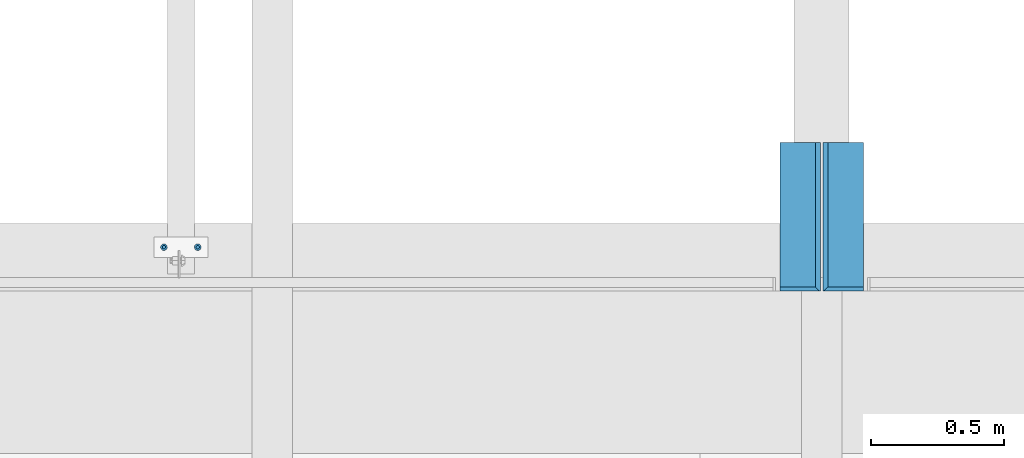
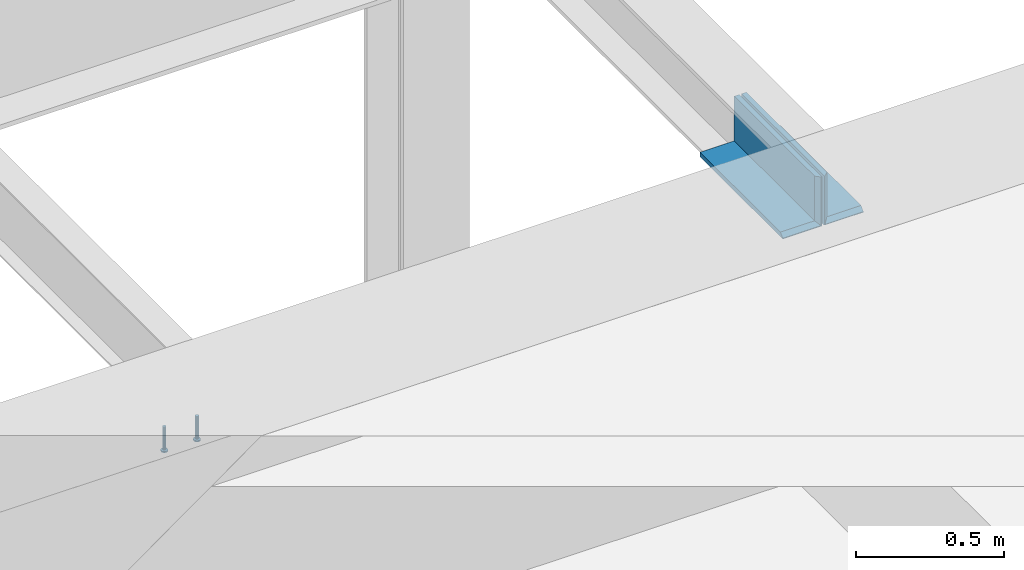
# One storey, part 1286 of 1763: 4 beams, 3 elements without a shape of their own.
"""IFC2X3 building model written with IfcOpenShell, lengths in millimetres."""

from ifc_helpers import new_model, si_unit, frame, origin_with_axes, place, context, subcontext, project, spatial, faceted_brep, material, type_object, element, aggregate, save


model = new_model("IFC2X3")

# Units and contexts
model_context = context("Model", 3, precision=1e-05, world=origin_with_axes())
body_context = subcontext(model_context, "Body", "Model", "MODEL_VIEW")
ifc_project = project(units=[si_unit("LENGTHUNIT", "METRE", prefix="MILLI"), si_unit("AREAUNIT", "SQUARE_METRE"), si_unit("VOLUMEUNIT", "CUBIC_METRE"), si_unit("MASSUNIT", "GRAM", prefix="KILO"), si_unit("TIMEUNIT", "SECOND"), si_unit("PLANEANGLEUNIT", "RADIAN"), si_unit("SOLIDANGLEUNIT", "STERADIAN"), si_unit("THERMODYNAMICTEMPERATUREUNIT", "DEGREE_CELSIUS"), si_unit("LUMINOUSINTENSITYUNIT", "LUMEN")], contexts=[model_context])

# Site, building, storey
site_placement = place(None, origin_with_axes())
site = spatial("IfcSite", under=ifc_project, at=site_placement, CompositionType="ELEMENT")
building_placement = place(site_placement, origin_with_axes())
building = spatial("IfcBuilding", under=site, at=building_placement, Name="Undefined", CompositionType="ELEMENT")
storey_placement = place(building_placement, origin_with_axes())
storey = spatial("IfcBuildingStorey", under=building, at=storey_placement, Name="Undefined", CompositionType="ELEMENT", Elevation=0.0)

# Assembly, beams
assembly_1_placement = place(storey_placement, origin_with_axes())
assembly_1 = element("IfcElementAssembly", 1, at=assembly_1_placement, inside=storey, Name="EMBED PLATE", AssemblyPlace="NOTDEFINED", PredefinedType="RIGID_FRAME")
ifc_material_1 = material(Name="STEEL/A108")
beam_type_1 = type_object("IfcBeamType", PredefinedType="NOTDEFINED")
beam_1_placement = place(assembly_1_placement, frame((-37295.1039434168, 27444.6999954224, 4879.975), z_axis=(1.0, 0.0, 0.0), x_axis=(0.0, 0.0, -1.0)))
beam_1 = element("IfcBeam", 2, at=beam_1_placement, type_object=beam_type_1, material=ifc_material_1, Name="HEADED STUD ANCHOR", context=body_context, shape_type="Brep", body=[
    faceted_brep([(0.0, -3.1800000667572, 5.5), (0.0, -5.5, 3.1800000667572), (94.4880000000003, -5.5, 3.1800000667572), (94.4880000000003, -3.1800000667572, 5.5), (0.0, -6.34999999999491, 1.45519152283669e-11), (94.4880000000003, -6.34999990463257, 0.0), (0.0, -5.5, -3.1800000667572), (94.4880000000003, -5.5, -3.1800000667572), (0.0, -3.1800000667572, -5.5), (94.4880000000003, -3.1800000667572, -5.5), (0.0, 0.0, -6.34999990463257), (94.4880000000003, 0.0, -6.34999990463257), (0.0, 3.1800000667572, -5.5), (94.4880000000003, 3.1800000667572, -5.5), (0.0, 5.5, -3.1800000667572), (94.4880000000003, 5.5, -3.1800000667572), (0.0, 6.34999999999491, -2.91038304567337e-11), (94.4880000000003, 6.34999990463257, 0.0), (0.0, 5.5, 3.1800000667572), (94.4880000000003, 5.5, 3.1800000667572), (0.0, 3.1800000667572, 5.5), (94.4880000000003, 3.1800000667572, 5.5), (0.0, 0.0, 6.34999990463257), (94.4880000000003, 0.0, 6.34999990463257), (96.5200000000004, -10.9899997711182, 6.34999990463257), (96.5200000000004, -6.34000015258789, 10.9899997711182), (96.5200000000004, -12.6999998092651, 0.0), (96.5200000000004, -10.9899997711182, -6.34999990463257), (96.5200000000004, -6.34000015258789, -10.9899997711182), (96.5200000000004, 0.0, -12.6899995803833), (96.5200000000004, 6.34000015258789, -10.9899997711182), (96.5200000000004, 10.9899997711182, -6.34999990463257), (96.5200000000004, 12.6999998092651, 0.0), (96.5200000000004, 10.9899997711182, 6.34999990463257), (96.5200000000004, 6.34000015258789, 10.9899997711182), (96.5200000000004, 0.0, 12.6899995803833), (101.6, -10.9899997711182, 6.34999990463257), (101.6, -6.34000015258789, 10.9899997711182), (101.6, -12.6999998092651, 0.0), (101.6, -10.9899997711182, -6.34999990463257), (101.6, -6.34000015258789, -10.9899997711182), (101.6, 0.0, -12.6899995803833), (101.6, 6.34000015258789, -10.9899997711182), (101.6, 10.9899997711182, -6.34999990463257), (101.6, 12.6999998092651, 0.0), (101.6, 10.9899997711182, 6.34999990463257), (101.6, 6.34000015258789, 10.9899997711182), (101.6, 0.0, 12.6899995803833)], [[[0, 1, 2, 3]], [[1, 4, 5, 2]], [[4, 6, 7, 5]], [[6, 8, 9, 7]], [[8, 10, 11, 9]], [[10, 12, 13, 11]], [[12, 14, 15, 13]], [[14, 16, 17, 15]], [[16, 18, 19, 17]], [[18, 20, 21, 19]], [[20, 22, 23, 21]], [[22, 0, 3, 23]], [[22, 20, 18, 16, 14, 12, 10, 8, 6, 4, 1, 0]], [[3, 2, 24, 25]], [[2, 5, 26, 24]], [[5, 7, 27, 26]], [[7, 9, 28, 27]], [[9, 11, 29, 28]], [[11, 13, 30, 29]], [[13, 15, 31, 30]], [[15, 17, 32, 31]], [[17, 19, 33, 32]], [[19, 21, 34, 33]], [[21, 23, 35, 34]], [[23, 3, 25, 35]], [[25, 24, 36, 37]], [[24, 26, 38, 36]], [[26, 27, 39, 38]], [[27, 28, 40, 39]], [[28, 29, 41, 40]], [[29, 30, 42, 41]], [[30, 31, 43, 42]], [[31, 32, 44, 43]], [[32, 33, 45, 44]], [[33, 34, 46, 45]], [[34, 35, 47, 46]], [[35, 25, 37, 47]], [[38, 39, 40, 41, 42, 43, 44, 45, 46, 47, 37, 36]]]),
])
beam_2_placement = place(assembly_1_placement, frame((-37422.103940365, 27444.6999954224, 4879.975), z_axis=(1.0, 0.0, 0.0), x_axis=(0.0, 0.0, -1.0)))
beam_2 = element("IfcBeam", 3, at=beam_2_placement, type_object=beam_type_1, material=ifc_material_1, Name="HEADED STUD ANCHOR", context=body_context, shape_type="Brep", body=[
    faceted_brep([(0.0, -3.1800000667572, 5.5), (0.0, -5.5, 3.1800000667572), (94.4880000000003, -5.5, 3.1800000667572), (94.4880000000003, -3.1800000667572, 5.5), (0.0, -6.34999999999491, 1.45519152283669e-11), (94.4880000000003, -6.34999990463257, 0.0), (0.0, -5.5, -3.1800000667572), (94.4880000000003, -5.5, -3.1800000667572), (0.0, -3.1800000667572, -5.5), (94.4880000000003, -3.1800000667572, -5.5), (0.0, 0.0, -6.34999990463257), (94.4880000000003, 0.0, -6.34999990463257), (0.0, 3.1800000667572, -5.5), (94.4880000000003, 3.1800000667572, -5.5), (0.0, 5.5, -3.1800000667572), (94.4880000000003, 5.5, -3.1800000667572), (0.0, 6.34999999999491, -2.91038304567337e-11), (94.4880000000003, 6.34999990463257, 0.0), (0.0, 5.5, 3.1800000667572), (94.4880000000003, 5.5, 3.1800000667572), (0.0, 3.1800000667572, 5.5), (94.4880000000003, 3.1800000667572, 5.5), (0.0, 0.0, 6.34999990463257), (94.4880000000003, 0.0, 6.34999990463257), (96.5200000000004, -10.9899997711182, 6.34999990463257), (96.5200000000004, -6.34000015258789, 10.9899997711182), (96.5200000000004, -12.6999998092651, 0.0), (96.5200000000004, -10.9899997711182, -6.34999990463257), (96.5200000000004, -6.34000015258789, -10.9899997711182), (96.5200000000004, 0.0, -12.6899995803833), (96.5200000000004, 6.34000015258789, -10.9899997711182), (96.5200000000004, 10.9899997711182, -6.34999990463257), (96.5200000000004, 12.6999998092651, 0.0), (96.5200000000004, 10.9899997711182, 6.34999990463257), (96.5200000000004, 6.34000015258789, 10.9899997711182), (96.5200000000004, 0.0, 12.6899995803833), (101.6, -10.9899997711182, 6.34999990463257), (101.6, -6.34000015258789, 10.9899997711182), (101.6, -12.6999998092651, 0.0), (101.6, -10.9899997711182, -6.34999990463257), (101.6, -6.34000015258789, -10.9899997711182), (101.6, 0.0, -12.6899995803833), (101.6, 6.34000015258789, -10.9899997711182), (101.6, 10.9899997711182, -6.34999990463257), (101.6, 12.6999998092651, 0.0), (101.6, 10.9899997711182, 6.34999990463257), (101.6, 6.34000015258789, 10.9899997711182), (101.6, 0.0, 12.6899995803833)], [[[0, 1, 2, 3]], [[1, 4, 5, 2]], [[4, 6, 7, 5]], [[6, 8, 9, 7]], [[8, 10, 11, 9]], [[10, 12, 13, 11]], [[12, 14, 15, 13]], [[14, 16, 17, 15]], [[16, 18, 19, 17]], [[18, 20, 21, 19]], [[20, 22, 23, 21]], [[22, 0, 3, 23]], [[22, 20, 18, 16, 14, 12, 10, 8, 6, 4, 1, 0]], [[3, 2, 24, 25]], [[2, 5, 26, 24]], [[5, 7, 27, 26]], [[7, 9, 28, 27]], [[9, 11, 29, 28]], [[11, 13, 30, 29]], [[13, 15, 31, 30]], [[15, 17, 32, 31]], [[17, 19, 33, 32]], [[19, 21, 34, 33]], [[21, 23, 35, 34]], [[23, 3, 25, 35]], [[25, 24, 36, 37]], [[24, 26, 38, 36]], [[26, 27, 39, 38]], [[27, 28, 40, 39]], [[28, 29, 41, 40]], [[29, 30, 42, 41]], [[30, 31, 43, 42]], [[31, 32, 44, 43]], [[32, 33, 45, 44]], [[33, 34, 46, 45]], [[34, 35, 47, 46]], [[35, 25, 37, 47]], [[38, 39, 40, 41, 42, 43, 44, 45, 46, 47, 37, 36]]]),
])
aggregate(assembly_1, [beam_1, beam_2])

# Assembly, beam
assembly_2_placement = place(storey_placement, origin_with_axes())
assembly_2 = element("IfcElementAssembly", 4, at=assembly_2_placement, inside=storey, Name="ANGLE", AssemblyPlace="NOTDEFINED", PredefinedType="RIGID_FRAME")
ifc_material_2 = material(Name="STEEL/A36")
beam_type_2 = type_object("IfcBeamType", Name="L8X6X3/4", PredefinedType="NOTDEFINED")
beam_3_placement = place(assembly_2_placement, frame((-34868.8747736984, 27279.6, 5041.9), z_axis=(0.0, 0.0, 1.0), x_axis=(0.0, 1.0, 0.0)))
beam_3 = element("IfcBeam", 5, at=beam_3_placement, type_object=beam_type_2, material=ifc_material_2, Name="ANGLE", ObjectType="L8X6X3/4", context=body_context, shape_type="Brep", body=[
    faceted_brep([(0.0, 73.0249999999942, -98.4250000000002), (15.875, 57.1499999999942, -82.5500000000002), (15.875, 57.1499999999942, 101.6), (0.0, 73.0249999999942, 101.6), (0.0, -76.1999999999971, -98.4250000000002), (15.875, -76.1999999999971, -82.5500000000002), (558.799999999999, 57.1499999999942, -82.5500000000002), (558.799999999999, 57.1499999999942, 101.6), (0.0, 76.1999999999971, -101.6), (0.0, 76.1999999999971, 101.6), (558.799999999999, 76.1999999999971, 101.6), (558.799999999999, 76.1999999999971, -101.6), (558.799999999999, -76.1999999999971, -82.5500000000002), (0.0, -76.1999999999971, -101.6), (558.799999999999, -76.1999999999971, -101.6)], [[[0, 1, 2, 3]], [[4, 5, 1, 0]], [[6, 7, 2, 1]], [[8, 9, 10, 11]], [[7, 10, 9, 3, 2]], [[12, 6, 1, 5]], [[13, 14, 12, 5, 4]], [[13, 8, 11, 14]], [[7, 6, 12, 14, 11, 10]], [[9, 8, 13, 4, 0, 3]]]),
])
aggregate(assembly_2, [beam_3])

assembly_3_placement = place(storey_placement, origin_with_axes())
assembly_3 = element("IfcElementAssembly", 6, at=assembly_3_placement, inside=storey, Name="ANGLE", AssemblyPlace="NOTDEFINED", PredefinedType="RIGID_FRAME")
beam_4_placement = place(assembly_3_placement, frame((-35030.7997736983, 27838.4, 5041.9), z_axis=(0.0, 0.0, 1.0), x_axis=(0.0, -1.0, 0.0)))
beam_4 = element("IfcBeam", 7, at=beam_4_placement, type_object=beam_type_2, material=ifc_material_2, Name="ANGLE", ObjectType="L8X6X3/4", context=body_context, shape_type="Brep", body=[
    faceted_brep([(558.799999999999, 73.0249999999942, -98.4250000000002), (542.924999999999, 57.1499999999942, -82.5500000000002), (542.924999999999, -76.1999999999971, -82.5500000000002), (558.799999999999, -76.1999999999971, -98.4250000000002), (558.799999999999, 73.0249999999942, 101.6), (542.924999999999, 57.1499999999942, 101.6), (0.0, 57.1499999999942, -82.5500000000002), (0.0, -76.1999999999971, -82.5500000000002), (0.0, 76.1999999999971, -101.6), (0.0, 76.1999999999971, 101.6), (558.799999999999, 76.1999999999971, 101.6), (558.799999999999, 76.1999999999971, -101.6), (0.0, 57.1499999999942, 101.6), (0.0, -76.1999999999971, -101.6), (558.799999999999, -76.1999999999971, -101.6)], [[[0, 1, 2, 3]], [[4, 5, 1, 0]], [[6, 7, 2, 1]], [[8, 9, 10, 11]], [[10, 9, 12, 5, 4]], [[12, 6, 1, 5]], [[7, 13, 14, 3, 2]], [[13, 8, 11, 14]], [[14, 11, 10, 4, 0, 3]], [[13, 7, 6, 12, 9, 8]]]),
])
aggregate(assembly_3, [beam_4])

save(model, "model.ifc")
